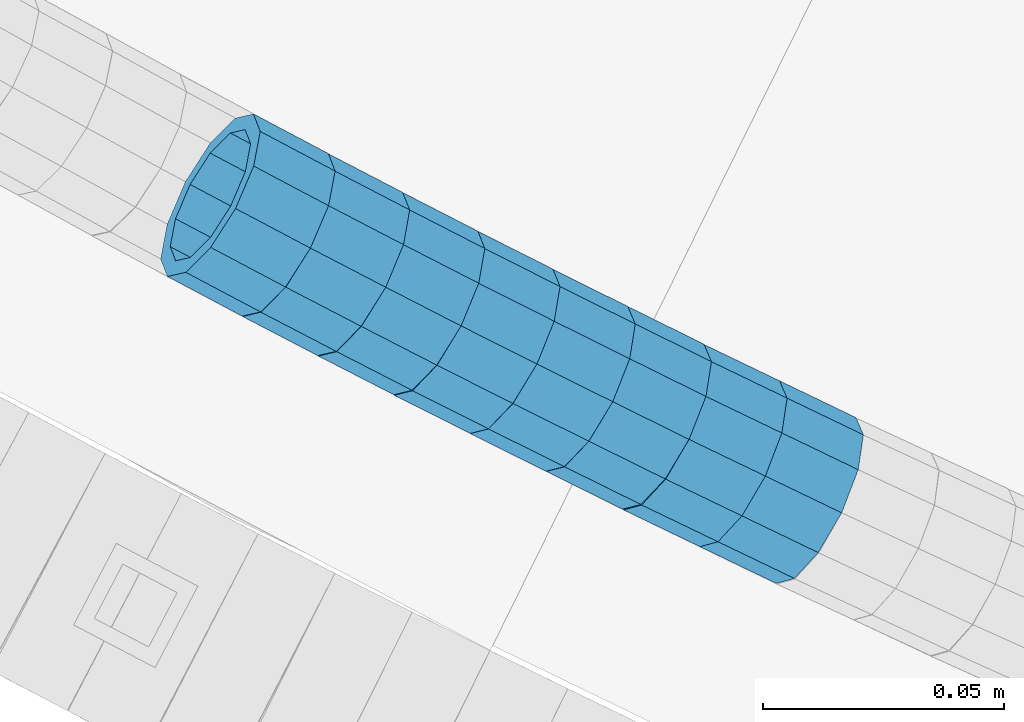
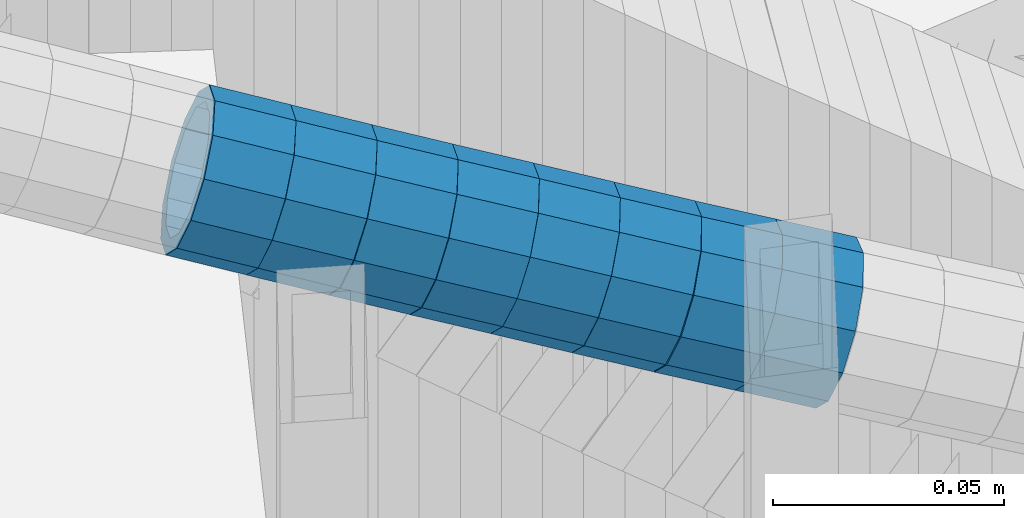
# One storey, part 647 of 975: 8 beams.
"""IFC2X3 building model written with IfcOpenShell, lengths in millimetres."""

import ifcopenshell
import ifcopenshell.guid

model = None  # the IFC model being written
_history = None  # IfcOwnerHistory: only IFC2X3 demands one
_inside = {}  # id of a spatial element -> (the spatial element, [elements in it])
_under = {}  # id of a project, library or spatial element -> (it, [spatial elements below it])
_declared = {}  # id of a project -> (the project, [libraries it declares])
_typed = {}  # id of a type object -> (the type object, [elements of that type])
_made_of = {}  # id of a material, layer set ... -> (it, [elements and type objects made of it])


def new_model(schema):
    """Start an empty IFC model of exactly this schema.

    Asked for "IFC4X3", IfcOpenShell would pick the latest addendum, in which some entities
    have other attributes; the version numbers below select the first issue.
    IFC2X3 requires an IfcOwnerHistory on every rooted entity: one is made here for all.
    """
    global model, _history
    if schema == "IFC4X3":
        model = ifcopenshell.file(schema_version=(4, 3, 0, 0))
    else:
        model = ifcopenshell.file(schema=schema)
    _inside.clear()
    _under.clear()
    _declared.clear()
    _typed.clear()
    _made_of.clear()
    _history = None
    if model.schema == "IFC2X3":
        org = make("IfcOrganization", Name="unknown")
        user = make(
            "IfcPersonAndOrganization",
            ThePerson=make("IfcPerson", FamilyName="unknown"),
            TheOrganization=org,
        )
        app = make(
            "IfcApplication",
            ApplicationDeveloper=org,
            Version="unknown",
            ApplicationFullName="unknown",
            ApplicationIdentifier="unknown",
        )
        _history = make(
            "IfcOwnerHistory",
            OwningUser=user,
            OwningApplication=app,
            ChangeAction="ADDED",
            CreationDate=0,
        )
    return model


def make(cls, **values):
    """One entity of the class cls with the attributes given. An attribute that is None is left unset."""
    return model.create_entity(
        cls, **{name: value for name, value in values.items() if value is not None}
    )


def rooted(cls, **values):
    """An entity with a GlobalId (a new one), such as an element, a storey or a relation."""
    return make(cls, GlobalId=ifcopenshell.guid.new(), OwnerHistory=_history, **values)


def si_unit(unit_type, name, prefix=None):
    """IfcSIUnit, for example si_unit("LENGTHUNIT", "METRE", prefix="MILLI")."""
    return make("IfcSIUnit", UnitType=unit_type, Prefix=prefix, Name=name)


def assignment(units):
    """IfcUnitAssignment: the units of a project."""
    return None if units is None else make("IfcUnitAssignment", Units=units)


def point(xyz):
    """IfcCartesianPoint."""
    return None if xyz is None else make("IfcCartesianPoint", Coordinates=xyz)


def direction(xyz):
    """IfcDirection."""
    return None if xyz is None else make("IfcDirection", DirectionRatios=xyz)


def frame(location, z_axis=None, x_axis=None):
    """IfcAxis2Placement3D, a coordinate frame: its origin and axes. An axis left out is left unset."""
    return make(
        "IfcAxis2Placement3D",
        Location=point(location),
        Axis=direction(z_axis),
        RefDirection=direction(x_axis),
    )


def origin_with_axes():
    """The frame at (0, 0, 0) with the z axis (0, 0, 1) and the x axis (1, 0, 0) written out."""
    return frame((0.0, 0.0, 0.0), z_axis=(0.0, 0.0, 1.0), x_axis=(1.0, 0.0, 0.0))


def place(relative_to, where):
    """IfcLocalPlacement: puts the frame where relative to a parent placement (None: the world)."""
    return make(
        "IfcLocalPlacement", PlacementRelTo=relative_to, RelativePlacement=where
    )


def context(
    kind, dimensions, precision=None, world=None, true_north=None, identifier=None
):
    """IfcGeometricRepresentationContext, for example the 3D "Model" context."""
    return make(
        "IfcGeometricRepresentationContext",
        ContextIdentifier=identifier,
        ContextType=kind,
        CoordinateSpaceDimension=dimensions,
        Precision=precision,
        WorldCoordinateSystem=world,
        TrueNorth=true_north,
    )


def subcontext(parent, identifier, kind, view, scale=None):
    """IfcGeometricRepresentationSubContext, for example "Body" below "Model"."""
    return make(
        "IfcGeometricRepresentationSubContext",
        ContextIdentifier=identifier,
        ContextType=kind,
        ParentContext=parent,
        TargetScale=scale,
        TargetView=view,
    )


def project(units=None, contexts=None):
    """IfcProject with its units and contexts."""
    return rooted(
        "IfcProject",
        Name="project",
        RepresentationContexts=contexts,
        UnitsInContext=assignment(units),
    )


def spatial(cls, under=None, at=None, **own):
    """A site, building, storey or space (cls), placed at a placement, below another one or the project."""
    s = rooted(cls, ObjectPlacement=at, **own)
    if under is not None:
        _under.setdefault(under.id(), (under, []))[1].append(s)
    return s


def faces_of(points, faces, orient=None, outer=None):
    """IfcFace entities. A face is a list of loops; a loop is a list of indices into points, from 0.

    orient and outer hold one flag for each loop. By default every Orientation is true, the
    first loop of a face is its IfcFaceOuterBound and the others are IfcFaceBound.
    """
    made = []
    for i, loops in enumerate(faces):
        bounds = []
        for j, loop in enumerate(loops):
            is_outer = j == 0 if outer is None else outer[i][j]
            bounds.append(
                make(
                    "IfcFaceOuterBound" if is_outer else "IfcFaceBound",
                    Bound=make("IfcPolyLoop", Polygon=[points[k] for k in loop]),
                    Orientation=True if orient is None else orient[i][j],
                )
            )
        made.append(make("IfcFace", Bounds=bounds))
    return made


def faceted_brep(points, faces, orient=None, outer=None, voids=None):
    """IfcFacetedBrep: a solid bounded by flat faces; with voids (closed shells), ...WithVoids."""
    shared = [point(p) for p in points]
    hull = make("IfcClosedShell", CfsFaces=faces_of(shared, faces, orient, outer))
    if voids is None:
        return make("IfcFacetedBrep", Outer=hull)
    return make(
        "IfcFacetedBrepWithVoids",
        Outer=hull,
        Voids=[
            make(cls, CfsFaces=faces_of(shared, fs, o, b)) for cls, fs, o, b in voids
        ],
    )


def shape(context_of_items, identifier, shape_type, items):
    """IfcShapeRepresentation: the items that make up one representation, for example the "Body"."""
    return make(
        "IfcShapeRepresentation",
        ContextOfItems=context_of_items,
        RepresentationIdentifier=identifier,
        RepresentationType=shape_type,
        Items=items,
    )


def material(Name=None, Category=None):
    """IfcMaterial."""
    return make("IfcMaterial", Name=Name, Category=Category)


def made_of(thing, what):
    """Note that an element or type object is made of a material, layer set ...; save() writes the relation."""
    if what is not None:
        _made_of.setdefault(what.id(), (what, []))[1].append(thing)
    return thing


def type_object(cls, material=None, **own):
    """A type object (cls), such as IfcWallType, which elements share."""
    return made_of(rooted(cls, **own), material)


def element(
    cls,
    number,
    at=None,
    inside=None,
    cuts=None,
    type_object=None,
    material=None,
    context=None,
    identifier="Body",
    shape_type=None,
    held_by="IfcProductDefinitionShape",
    body=None,
    shapes=None,
    **own,
):
    """One element of the class cls, such as IfcWall. Its Tag is "e" and its number.

    at: its placement. inside: the storey or other place that contains it. cuts: it is an
    opening in that element (IfcRelVoidsElement). A single representation is given by context,
    identifier, shape_type and body (its items); several are given by shapes. held_by: the class
    of the entity that holds the representations. save() writes the other relations.
    """
    e = rooted(cls, Tag="e%d" % number, ObjectPlacement=at, **own)
    if body is not None:
        shapes = [shape(context, identifier, shape_type, body)]
    if shapes is not None:
        e.Representation = make(held_by, Representations=shapes)
    if inside is not None:
        _inside.setdefault(inside.id(), (inside, []))[1].append(e)
    if cuts is not None:
        rooted(
            "IfcRelVoidsElement", RelatingBuildingElement=cuts, RelatedOpeningElement=e
        )
    if type_object is not None:
        _typed.setdefault(type_object.id(), (type_object, []))[1].append(e)
    return made_of(e, material)


def aggregate(whole, parts):
    """IfcRelAggregates: a whole, such as a stair, and the parts it consists of."""
    return rooted("IfcRelAggregates", RelatingObject=whole, RelatedObjects=parts)


def save(model, path):
    """Write the relations noted so far, then the file.

    IfcRelAggregates (storeys below a building ...), IfcRelContainedInSpatialStructure (elements
    in a storey), IfcRelDefinesByType, IfcRelAssociatesMaterial and IfcRelDeclares: one each for
    every whole, place, type object, material and project.
    """
    for whole, parts in _under.values():
        aggregate(whole, parts)
    for where, things in _inside.values():
        rooted(
            "IfcRelContainedInSpatialStructure",
            RelatedElements=things,
            RelatingStructure=where,
        )
    for kind, things in _typed.values():
        rooted("IfcRelDefinesByType", RelatedObjects=things, RelatingType=kind)
    for what, things in _made_of.values():
        rooted("IfcRelAssociatesMaterial", RelatedObjects=things, RelatingMaterial=what)
    for by, libraries in _declared.values():
        rooted("IfcRelDeclares", RelatingContext=by, RelatedDefinitions=libraries)
    model.write(path)


model = new_model("IFC2X3")

# Units and contexts
model_context = context("Model", 3, precision=1e-05, world=origin_with_axes())
body_context = subcontext(model_context, "Body", "Model", "MODEL_VIEW")
ifc_project = project(units=[si_unit("LENGTHUNIT", "METRE", prefix="MILLI"), si_unit("AREAUNIT", "SQUARE_METRE"), si_unit("VOLUMEUNIT", "CUBIC_METRE"), si_unit("MASSUNIT", "GRAM", prefix="KILO"), si_unit("TIMEUNIT", "SECOND"), si_unit("PLANEANGLEUNIT", "RADIAN"), si_unit("SOLIDANGLEUNIT", "STERADIAN"), si_unit("THERMODYNAMICTEMPERATUREUNIT", "DEGREE_CELSIUS"), si_unit("LUMINOUSINTENSITYUNIT", "LUMEN")], contexts=[model_context])

# Site, building, storey
site_placement = place(None, origin_with_axes())
site = spatial("IfcSite", under=ifc_project, at=site_placement, CompositionType="ELEMENT")
building_placement = place(site_placement, origin_with_axes())
building = spatial("IfcBuilding", under=site, at=building_placement, Name="Undefined", CompositionType="ELEMENT")
storey_placement = place(building_placement, origin_with_axes())
storey = spatial("IfcBuildingStorey", under=building, at=storey_placement, Name="Undefined", CompositionType="ELEMENT", Elevation=0.0)

# Beams
ifc_material = material()
beam_type = type_object("IfcBeamType", PredefinedType="NOTDEFINED")
beam_1_placement = place(storey_placement, frame((33416.0911510249, 947.261249186735, 4658.7831039662), z_axis=(0.467625681681325, 0.883926593011024, 9.3239577836357e-11), x_axis=(0.840630248711219, -0.444720518847201, -0.309134994893801)))
element("IfcBeam", 1, at=beam_1_placement, inside=storey, type_object=beam_type, material=ifc_material, Name="WALL", context=body_context, shape_type="Brep", body=[
    faceted_brep([(-2.1246523829177e-07, -15.367000000002, 0.0), (-1.83998054126278e-07, -13.3082123799541, 7.68350000000009), (18.4442402933746, -13.3082123799431, 7.68349999998463), (18.4442402933928, -15.3669999999893, -3.63797880709171e-12), (-1.06232619145885e-07, -7.68349999999919, 13.3082123799559), (18.4442402933564, -7.68349999998281, 13.308212379925), (-3.63797880709171e-12, 3.63797880709171e-12, 15.3670000000002), (18.4442402933455, 1.81898940354586e-11, 15.3669999999584), (1.06225343188271e-07, 7.68350000000646, 13.3082123799559), (18.4442402933419, 7.68350000001737, 13.3082123799104), (1.8399441614747e-07, 13.308212379965, 7.68350000000009), (18.4442402933528, 13.3082123799722, 7.68349999996281), (2.12461600312963e-07, 15.3670000000093, 0.0), (18.4442402933637, 15.3670000000129, -2.5465851649642e-11), (1.8399441614747e-07, 13.308212379965, -7.68350000000009), (18.4442402933855, 13.308212379965, -7.6835000000101), (1.06225343188271e-07, 7.68350000000646, -13.3082123799559), (18.4442402934037, 7.68350000000646, -13.3082123799541), (-3.63797880709171e-12, 3.63797880709171e-12, -15.3670000000002), (18.444240293411, 5.45696821063757e-12, -15.3669999999911), (-1.06232619145885e-07, -7.68349999999919, -13.3082123799559), (18.4442402934146, -7.68349999999373, -13.3082123799431), (-1.83998054126278e-07, -13.3082123799541, -7.68350000000009), (18.4442402934037, -13.3082123799468, -7.68349999999191), (-2.63386027654633e-07, -19.0500000000029, 0.0), (-2.28097633225843e-07, -16.4977839420972, -9.52499999999964), (18.444240293411, -16.4977839420862, -9.5249999999869), (18.4442402933964, -19.0499999999902, 0.0), (-1.31691194837913e-07, -9.52500000000146, -16.4977839420935), (18.4442402934219, -9.524999999996, -16.4977839420717), (-3.63797880709171e-12, 3.63797880709171e-12, -19.0500000000002), (18.4442402934183, 3.63797880709171e-12, -19.0499999999847), (1.31687556859106e-07, 9.52500000000509, -16.4977839420935), (18.4442402934073, 9.52500000000509, -16.4977839420899), (2.28097633225843e-07, 16.4977839421044, -9.52499999999964), (18.4442402933855, 16.4977839421008, -9.52500000001601), (2.63382389675826e-07, 19.0500000000138, 0.0), (18.4442402933637, 19.0500000000138, -2.91038304567337e-11), (2.28097633225843e-07, 16.4977839421044, 9.52499999999964), (18.4442402933419, 16.4977839421117, 9.52499999995052), (1.31687556859106e-07, 9.52500000000509, 16.4977839420935), (18.4442402933346, 9.52500000001965, 16.4977839420426), (-3.63797880709171e-12, 3.63797880709171e-12, 19.0500000000002), (18.4442402933346, 2.00088834390044e-11, 19.0499999999483), (-1.31691194837913e-07, -9.52500000000146, 16.4977839420935), (18.4442402933528, -9.52499999998145, 16.4977839420571), (-2.28097633225843e-07, -16.4977839420972, 9.52499999999964), (18.4442402933746, -16.497783942079, 9.52499999998327)], [[[0, 1, 2, 3]], [[1, 4, 5, 2]], [[4, 6, 7, 5]], [[6, 8, 9, 7]], [[8, 10, 11, 9]], [[10, 12, 13, 11]], [[12, 14, 15, 13]], [[14, 16, 17, 15]], [[16, 18, 19, 17]], [[18, 20, 21, 19]], [[20, 22, 23, 21]], [[22, 0, 3, 23]], [[24, 25, 26, 27]], [[25, 28, 29, 26]], [[28, 30, 31, 29]], [[30, 32, 33, 31]], [[32, 34, 35, 33]], [[34, 36, 37, 35]], [[36, 38, 39, 37]], [[38, 40, 41, 39]], [[40, 42, 43, 41]], [[42, 44, 45, 43]], [[44, 46, 47, 45]], [[46, 24, 27, 47]], [[29, 31, 33, 35, 37, 39, 41, 43, 45, 47, 27, 26], [5, 7, 9, 11, 13, 15, 17, 19, 21, 23, 3, 2]], [[46, 44, 42, 40, 38, 36, 34, 32, 30, 28, 25, 24], [22, 20, 18, 16, 14, 12, 10, 8, 6, 4, 1, 0]]]),
])
beam_2_placement = place(storey_placement, frame((33431.4988890228, 939.058133171127, 4653.10939389634), z_axis=(0.460815270795851, 0.887496076724481, 1.78888512891718e-11), x_axis=(0.842800104689895, -0.437607746838989, -0.31334875688473)))
element("IfcBeam", 2, at=beam_2_placement, inside=storey, type_object=beam_type, material=ifc_material, Name="WALL", context=body_context, shape_type="Brep", body=[
    faceted_brep([(-2.1246523829177e-07, -15.367000000002, 0.0), (-1.83998054126278e-07, -13.3082123799541, 7.68350000000009), (18.5143187830763, -13.3082123799722, 7.68350000001374), (18.5143187830618, -15.3670000000093, 3.63797880709171e-12), (-1.06232619145885e-07, -7.68349999999919, 13.3082123799559), (18.5143187830836, -7.68350000002101, 13.3082123799722), (-3.63797880709171e-12, 3.63797880709171e-12, 15.3670000000002), (18.5143187830763, -1.81898940354586e-11, 15.3670000000166), (1.06225343188271e-07, 7.68350000000646, 13.3082123799559), (18.5143187830581, 7.68349999999009, 13.3082123799613), (1.8399441614747e-07, 13.308212379965, 7.68350000000009), (18.5143187830363, 13.3082123799559, 7.68349999999191), (2.12461600312963e-07, 15.3670000000093, 0.0), (18.5143187830108, 15.3670000000111, -2.18278728425503e-11), (1.8399441614747e-07, 13.308212379965, -7.68350000000009), (18.514318782989, 13.3082123799722, -7.68350000003193), (1.06225343188271e-07, 7.68350000000646, -13.3082123799559), (18.5143187829854, 7.68350000002101, -13.3082123799904), (-3.63797880709171e-12, 3.63797880709171e-12, -15.3670000000002), (18.5143187829926, 1.81898940354586e-11, -15.3670000000311), (-1.06232619145885e-07, -7.68349999999919, -13.3082123799559), (18.5143187830108, -7.68349999999191, -13.3082123799795), (-1.83998054126278e-07, -13.3082123799541, -7.68350000000009), (18.5143187830363, -13.3082123799559, -7.6835000000101), (-2.63386027654633e-07, -19.0500000000029, 0.0), (-2.28097633225843e-07, -16.4977839420972, -9.52499999999964), (18.5143187830363, -16.4977839420935, -9.52500000000873), (18.5143187830654, -19.0500000000102, 7.27595761418343e-12), (-1.31691194837913e-07, -9.52500000000146, -16.4977839420935), (18.5143187830035, -9.5249999999869, -16.497783942119), (-3.63797880709171e-12, 3.63797880709171e-12, -19.0500000000002), (18.5143187829854, 2.00088834390044e-11, -19.0500000000357), (1.31687556859106e-07, 9.52500000000509, -16.4977839420935), (18.5143187829744, 9.5250000000251, -16.4977839421408), (2.28097633225843e-07, 16.4977839421044, -9.52499999999964), (18.5143187829854, 16.4977839421135, -9.52500000003783), (2.63382389675826e-07, 19.0500000000138, 0.0), (18.5143187830035, 19.050000000012, -2.5465851649642e-11), (2.28097633225843e-07, 16.4977839421044, 9.52499999999964), (18.5143187830326, 16.4977839420935, 9.52499999999054), (1.31687556859106e-07, 9.52500000000509, 16.4977839420935), (18.5143187830654, 9.52499999998872, 16.4977839421008), (-3.63797880709171e-12, 3.63797880709171e-12, 19.0500000000002), (18.5143187830836, -1.81898940354586e-11, 19.0500000000211), (-1.31691194837913e-07, -9.52500000000146, 16.4977839420935), (18.5143187830981, -9.52500000002328, 16.4977839421226), (-2.28097633225843e-07, -16.4977839420972, 9.52499999999964), (18.5143187830872, -16.4977839421135, 9.52500000001965)], [[[0, 1, 2, 3]], [[1, 4, 5, 2]], [[4, 6, 7, 5]], [[6, 8, 9, 7]], [[8, 10, 11, 9]], [[10, 12, 13, 11]], [[12, 14, 15, 13]], [[14, 16, 17, 15]], [[16, 18, 19, 17]], [[18, 20, 21, 19]], [[20, 22, 23, 21]], [[22, 0, 3, 23]], [[24, 25, 26, 27]], [[25, 28, 29, 26]], [[28, 30, 31, 29]], [[30, 32, 33, 31]], [[32, 34, 35, 33]], [[34, 36, 37, 35]], [[36, 38, 39, 37]], [[38, 40, 41, 39]], [[40, 42, 43, 41]], [[42, 44, 45, 43]], [[44, 46, 47, 45]], [[46, 24, 27, 47]], [[29, 31, 33, 35, 37, 39, 41, 43, 45, 47, 27, 26], [5, 7, 9, 11, 13, 15, 17, 19, 21, 23, 3, 2]], [[46, 44, 42, 40, 38, 36, 34, 32, 30, 28, 25, 24], [22, 20, 18, 16, 14, 12, 10, 8, 6, 4, 1, 0]]]),
])
beam_3_placement = place(storey_placement, frame((33447.1554574251, 930.895163959416, 4647.28347009415), z_axis=(0.456316647774038, 0.889817462721577, 2.40652298089117e-11), x_axis=(0.846215471031534, -0.433956652016189, -0.309194115011557)))
element("IfcBeam", 3, at=beam_3_placement, inside=storey, type_object=beam_type, material=ifc_material, Name="WALL", context=body_context, shape_type="Brep", body=[
    faceted_brep([(-2.1246523829177e-07, -15.367000000002, 0.0), (-1.83998054126278e-07, -13.3082123799541, 7.68350000000009), (18.4442402933746, -13.3082123799431, 7.68349999998463), (18.4442402933928, -15.3669999999893, -3.63797880709171e-12), (-1.06232619145885e-07, -7.68349999999919, 13.3082123799559), (18.4442402933564, -7.68349999998281, 13.308212379925), (-3.63797880709171e-12, 3.63797880709171e-12, 15.3670000000002), (18.4442402933455, 1.81898940354586e-11, 15.3669999999584), (1.06225343188271e-07, 7.68350000000646, 13.3082123799559), (18.4442402933419, 7.68350000001737, 13.3082123799104), (1.8399441614747e-07, 13.308212379965, 7.68350000000009), (18.4442402933528, 13.3082123799722, 7.68349999996281), (2.12461600312963e-07, 15.3670000000093, 0.0), (18.4442402933637, 15.3670000000129, -2.5465851649642e-11), (1.8399441614747e-07, 13.308212379965, -7.68350000000009), (18.4442402933855, 13.308212379965, -7.6835000000101), (1.06225343188271e-07, 7.68350000000646, -13.3082123799559), (18.4442402934037, 7.68350000000646, -13.3082123799541), (-3.63797880709171e-12, 3.63797880709171e-12, -15.3670000000002), (18.444240293411, 5.45696821063757e-12, -15.3669999999911), (-1.06232619145885e-07, -7.68349999999919, -13.3082123799559), (18.4442402934146, -7.68349999999373, -13.3082123799431), (-1.83998054126278e-07, -13.3082123799541, -7.68350000000009), (18.4442402934037, -13.3082123799468, -7.68349999999191), (-2.63386027654633e-07, -19.0500000000029, 0.0), (-2.28097633225843e-07, -16.4977839420972, -9.52499999999964), (18.444240293411, -16.4977839420862, -9.5249999999869), (18.4442402933964, -19.0499999999902, 0.0), (-1.31691194837913e-07, -9.52500000000146, -16.4977839420935), (18.4442402934219, -9.524999999996, -16.4977839420717), (-3.63797880709171e-12, 3.63797880709171e-12, -19.0500000000002), (18.4442402934183, 3.63797880709171e-12, -19.0499999999847), (1.31687556859106e-07, 9.52500000000509, -16.4977839420935), (18.4442402934073, 9.52500000000509, -16.4977839420899), (2.28097633225843e-07, 16.4977839421044, -9.52499999999964), (18.4442402933855, 16.4977839421008, -9.52500000001601), (2.63382389675826e-07, 19.0500000000138, 0.0), (18.4442402933637, 19.0500000000138, -2.91038304567337e-11), (2.28097633225843e-07, 16.4977839421044, 9.52499999999964), (18.4442402933419, 16.4977839421117, 9.52499999995052), (1.31687556859106e-07, 9.52500000000509, 16.4977839420935), (18.4442402933346, 9.52500000001965, 16.4977839420426), (-3.63797880709171e-12, 3.63797880709171e-12, 19.0500000000002), (18.4442402933346, 2.00088834390044e-11, 19.0499999999483), (-1.31691194837913e-07, -9.52500000000146, 16.4977839420935), (18.4442402933528, -9.52499999998145, 16.4977839420571), (-2.28097633225843e-07, -16.4977839420972, 9.52499999999964), (18.4442402933746, -16.497783942079, 9.52499999998327)], [[[0, 1, 2, 3]], [[1, 4, 5, 2]], [[4, 6, 7, 5]], [[6, 8, 9, 7]], [[8, 10, 11, 9]], [[10, 12, 13, 11]], [[12, 14, 15, 13]], [[14, 16, 17, 15]], [[16, 18, 19, 17]], [[18, 20, 21, 19]], [[20, 22, 23, 21]], [[22, 0, 3, 23]], [[24, 25, 26, 27]], [[25, 28, 29, 26]], [[28, 30, 31, 29]], [[30, 32, 33, 31]], [[32, 34, 35, 33]], [[34, 36, 37, 35]], [[36, 38, 39, 37]], [[38, 40, 41, 39]], [[40, 42, 43, 41]], [[42, 44, 45, 43]], [[44, 46, 47, 45]], [[46, 24, 27, 47]], [[29, 31, 33, 35, 37, 39, 41, 43, 45, 47, 27, 26], [5, 7, 9, 11, 13, 15, 17, 19, 21, 23, 3, 2]], [[46, 44, 42, 40, 38, 36, 34, 32, 30, 28, 25, 24], [22, 20, 18, 16, 14, 12, 10, 8, 6, 4, 1, 0]]]),
])
beam_4_placement = place(storey_placement, frame((33462.7469060079, 922.848964169465, 4641.5791512697), z_axis=(0.449488036364084, 0.893286351158216, 2.07292941922788e-10), x_axis=(0.849716897215039, -0.427564553108204, -0.308495944078084)))
element("IfcBeam", 4, at=beam_4_placement, inside=storey, type_object=beam_type, material=ifc_material, Name="WALL", context=body_context, shape_type="Brep", body=[
    faceted_brep([(-2.1246523829177e-07, -15.367000000002, 0.0), (-1.83998054126278e-07, -13.3082123799541, 7.68350000000009), (18.4753890351749, -13.3082123799613, 7.6835000000101), (18.4753890351676, -15.3670000000056, 0.0), (-1.06232619145885e-07, -7.68349999999919, 13.3082123799559), (18.4753890351822, -7.6835000000101, 13.3082123799686), (-3.63797880709171e-12, 3.63797880709171e-12, 15.3670000000002), (18.4753890351967, -1.2732925824821e-11, 15.3670000000238), (1.06225343188271e-07, 7.68350000000646, 13.3082123799559), (18.475389035204, 7.68349999998463, 13.3082123799832), (1.8399441614747e-07, 13.308212379965, 7.68350000000009), (18.4753890352004, 13.3082123799395, 7.68350000002465), (2.12461600312963e-07, 15.3670000000093, 0.0), (18.4753890351967, 15.3669999999838, 2.5465851649642e-11), (1.8399441614747e-07, 13.308212379965, -7.68350000000009), (18.4753890351894, 13.3082123799413, -7.68349999998463), (1.06225343188271e-07, 7.68350000000646, -13.3082123799559), (18.4753890351749, 7.68349999998827, -13.3082123799468), (-3.63797880709171e-12, 3.63797880709171e-12, -15.3670000000002), (18.4753890351676, -1.09139364212751e-11, -15.3669999999947), (-1.06232619145885e-07, -7.68349999999919, -13.3082123799559), (18.4753890351676, -7.68350000000646, -13.3082123799577), (-1.83998054126278e-07, -13.3082123799541, -7.68350000000009), (18.4753890351567, -13.3082123799613, -7.68350000000282), (-2.63386027654633e-07, -19.0500000000029, 0.0), (-2.28097633225843e-07, -16.4977839420972, -9.52499999999964), (18.4753890351567, -16.4977839420972, -9.52500000000873), (18.4753890351676, -19.0500000000065, 0.0), (-1.31691194837913e-07, -9.52500000000146, -16.4977839420935), (18.475389035164, -9.52500000000873, -16.4977839420972), (-3.63797880709171e-12, 3.63797880709171e-12, -19.0500000000002), (18.475389035164, -9.09494701772928e-12, -19.0499999999993), (1.31687556859106e-07, 9.52500000000509, -16.4977839420935), (18.4753890351822, 9.5249999999869, -16.497783942079), (2.28097633225843e-07, 16.4977839421044, -9.52499999999964), (18.4753890351931, 16.497783942079, -9.52499999997963), (2.63382389675826e-07, 19.0500000000138, 0.0), (18.475389035204, 19.0499999999847, 2.91038304567337e-11), (2.28097633225843e-07, 16.4977839421044, 9.52499999999964), (18.4753890352113, 16.4977839420753, 9.5250000000342), (1.31687556859106e-07, 9.52500000000509, 16.4977839420935), (18.475389035204, 9.52499999998327, 16.4977839421226), (-3.63797880709171e-12, 3.63797880709171e-12, 19.0500000000002), (18.4753890352004, -1.45519152283669e-11, 19.0500000000284), (-1.31691194837913e-07, -9.52500000000146, 16.4977839420935), (18.4753890351858, -9.52500000000873, 16.4977839421081), (-2.28097633225843e-07, -16.4977839420972, 9.52499999999964), (18.4753890351749, -16.4977839421008, 9.52500000000509)], [[[0, 1, 2, 3]], [[1, 4, 5, 2]], [[4, 6, 7, 5]], [[6, 8, 9, 7]], [[8, 10, 11, 9]], [[10, 12, 13, 11]], [[12, 14, 15, 13]], [[14, 16, 17, 15]], [[16, 18, 19, 17]], [[18, 20, 21, 19]], [[20, 22, 23, 21]], [[22, 0, 3, 23]], [[24, 25, 26, 27]], [[25, 28, 29, 26]], [[28, 30, 31, 29]], [[30, 32, 33, 31]], [[32, 34, 35, 33]], [[34, 36, 37, 35]], [[36, 38, 39, 37]], [[38, 40, 41, 39]], [[40, 42, 43, 41]], [[42, 44, 45, 43]], [[44, 46, 47, 45]], [[46, 24, 27, 47]], [[29, 31, 33, 35, 37, 39, 41, 43, 45, 47, 27, 26], [5, 7, 9, 11, 13, 15, 17, 19, 21, 23, 3, 2]], [[46, 44, 42, 40, 38, 36, 34, 32, 30, 28, 25, 24], [22, 20, 18, 16, 14, 12, 10, 8, 6, 4, 1, 0]]]),
])
beam_5_placement = place(storey_placement, frame((33478.3378815538, 914.969691555199, 4635.91413137574), z_axis=(0.444930445702484, 0.895565127998511, 8.79335857462137e-11), x_axis=(0.850240068166291, -0.422412263082608, -0.314101427061402)))
element("IfcBeam", 5, at=beam_5_placement, inside=storey, type_object=beam_type, material=ifc_material, Name="WALL", context=body_context, shape_type="Brep", body=[
    faceted_brep([(-2.1246523829177e-07, -15.367000000002, 0.0), (-1.83998054126278e-07, -13.3082123799541, 7.68350000000009), (18.4672683416502, -13.3082123799759, 7.68350000002465), (18.4672683416611, -15.3670000000202, 3.09228198602796e-11), (-1.06232619145885e-07, -7.68349999999919, 13.3082123799559), (18.467268341632, -7.68350000001737, 13.3082123799704), (-3.63797880709171e-12, 3.63797880709171e-12, 15.3670000000002), (18.4672683416175, -1.09139364212751e-11, 15.3670000000075), (1.06225343188271e-07, 7.68350000000646, 13.3082123799559), (18.4672683416102, 7.68349999998827, 13.3082123799613), (1.8399441614747e-07, 13.308212379965, 7.68350000000009), (18.4672683416138, 13.3082123799468, 7.68350000000464), (2.12461600312963e-07, 15.3670000000093, 0.0), (18.4672683416138, 15.3669999999929, 5.45696821063757e-12), (1.8399441614747e-07, 13.308212379965, -7.68350000000009), (18.4672683416284, 13.308212379945, -7.68349999998827), (1.06225343188271e-07, 7.68350000000646, -13.3082123799559), (18.4672683416429, 7.68349999998827, -13.3082123799359), (-3.63797880709171e-12, 3.63797880709171e-12, -15.3670000000002), (18.4672683416611, -1.63709046319127e-11, -15.3669999999747), (-1.06232619145885e-07, -7.68349999999919, -13.3082123799559), (18.4672683416647, -7.68350000001919, -13.3082123799268), (-1.83998054126278e-07, -13.3082123799541, -7.68350000000009), (18.4672683416684, -13.3082123799759, -7.68349999997008), (-2.63386027654633e-07, -19.0500000000029, 0.0), (-2.28097633225843e-07, -16.4977839420972, -9.52499999999964), (18.4672683416793, -16.4977839421172, -9.52499999996508), (18.467268341672, -19.0500000000247, 3.27418092638254e-11), (-1.31691194837913e-07, -9.52500000000146, -16.4977839420935), (18.4672683416757, -9.52500000002328, -16.497783942059), (-3.63797880709171e-12, 3.63797880709171e-12, -19.0500000000002), (18.4672683416611, -1.45519152283669e-11, -19.0499999999738), (1.31687556859106e-07, 9.52500000000509, -16.4977839420935), (18.4672683416502, 9.5249999999869, -16.4977839420735), (2.28097633225843e-07, 16.4977839421044, -9.52499999999964), (18.4672683416247, 16.4977839420862, -9.52499999998872), (2.63382389675826e-07, 19.0500000000138, 0.0), (18.4672683416029, 19.0499999999956, 1.81898940354586e-12), (2.28097633225843e-07, 16.4977839421044, 9.52499999999964), (18.4672683416065, 16.4977839420862, 9.52500000000146), (1.31687556859106e-07, 9.52500000000509, 16.4977839420935), (18.4672683415993, 9.52499999999236, 16.4977839420917), (-3.63797880709171e-12, 3.63797880709171e-12, 19.0500000000002), (18.4672683416138, -1.45519152283669e-11, 19.0500000000084), (-1.31691194837913e-07, -9.52500000000146, 16.4977839420935), (18.4672683416356, -9.52500000001783, 16.4977839421117), (-2.28097633225843e-07, -16.4977839420972, 9.52499999999964), (18.4672683416538, -16.4977839421135, 9.5250000000251)], [[[0, 1, 2, 3]], [[1, 4, 5, 2]], [[4, 6, 7, 5]], [[6, 8, 9, 7]], [[8, 10, 11, 9]], [[10, 12, 13, 11]], [[12, 14, 15, 13]], [[14, 16, 17, 15]], [[16, 18, 19, 17]], [[18, 20, 21, 19]], [[20, 22, 23, 21]], [[22, 0, 3, 23]], [[24, 25, 26, 27]], [[25, 28, 29, 26]], [[28, 30, 31, 29]], [[30, 32, 33, 31]], [[32, 34, 35, 33]], [[34, 36, 37, 35]], [[36, 38, 39, 37]], [[38, 40, 41, 39]], [[40, 42, 43, 41]], [[42, 44, 45, 43]], [[44, 46, 47, 45]], [[46, 24, 27, 47]], [[29, 31, 33, 35, 37, 39, 41, 43, 45, 47, 27, 26], [5, 7, 9, 11, 13, 15, 17, 19, 21, 23, 3, 2]], [[46, 44, 42, 40, 38, 36, 34, 32, 30, 28, 25, 24], [22, 20, 18, 16, 14, 12, 10, 8, 6, 4, 1, 0]]]),
])
beam_6_placement = place(storey_placement, frame((33494.0557895983, 907.144000874222, 4630.10507295885), z_axis=(0.442667652479141, 0.896685758473171, 2.22678863792681e-10), x_axis=(0.851730363913507, -0.420474482957295, -0.312660512968235)))
element("IfcBeam", 6, at=beam_6_placement, inside=storey, type_object=beam_type, material=ifc_material, Name="WALL", context=body_context, shape_type="Brep", body=[
    faceted_brep([(-2.1246523829177e-07, -15.367000000002, 0.0), (-1.83998054126278e-07, -13.3082123799541, 7.68350000000009), (18.5504716921532, -13.3082123799668, 7.68350000001737), (18.5504716921569, -15.3670000000111, 1.81898940354586e-11), (-1.06232619145885e-07, -7.68349999999919, 13.3082123799559), (18.5504716921569, -7.68350000001192, 13.3082123799722), (-3.63797880709171e-12, 3.63797880709171e-12, 15.3670000000002), (18.5504716921641, -1.2732925824821e-11, 15.3670000000238), (1.06225343188271e-07, 7.68350000000646, 13.3082123799559), (18.5504716921714, 7.68349999998645, 13.3082123799868), (1.8399441614747e-07, 13.308212379965, 7.68350000000009), (18.5504716921787, 13.308212379945, 7.68350000003193), (2.12461600312963e-07, 15.3670000000093, 0.0), (18.5504716921787, 15.3669999999929, 3.27418092638254e-11), (1.8399441614747e-07, 13.308212379965, -7.68350000000009), (18.5504716921787, 13.3082123799522, -7.68349999997008), (1.06225343188271e-07, 7.68350000000646, -13.3082123799559), (18.5504716921787, 7.68349999999555, -13.3082123799213), (-3.63797880709171e-12, 3.63797880709171e-12, -15.3670000000002), (18.5504716921714, -3.63797880709171e-12, -15.3669999999765), (-1.06232619145885e-07, -7.68349999999919, -13.3082123799559), (18.5504716921641, -7.68350000000464, -13.3082123799359), (-1.83998054126278e-07, -13.3082123799541, -7.68350000000009), (18.5504716921605, -13.3082123799632, -7.683499999981), (-2.63386027654633e-07, -19.0500000000029, 0.0), (-2.28097633225843e-07, -16.4977839420972, -9.52499999999964), (18.5504716921569, -16.4977839421026, -9.52499999997963), (18.5504716921532, -19.0500000000102, 1.09139364212751e-11), (-1.31691194837913e-07, -9.52500000000146, -16.4977839420935), (18.5504716921605, -9.52500000000509, -16.4977839420681), (-3.63797880709171e-12, 3.63797880709171e-12, -19.0500000000002), (18.5504716921678, -1.81898940354586e-12, -19.0499999999774), (1.31687556859106e-07, 9.52500000000509, -16.4977839420935), (18.5504716921823, 9.52499999999782, -16.4977839420608), (2.28097633225843e-07, 16.4977839421044, -9.52499999999964), (18.550471692186, 16.4977839420881, -9.52499999996508), (2.63382389675826e-07, 19.0500000000138, 0.0), (18.550471692186, 19.049999999992, 3.63797880709171e-11), (2.28097633225843e-07, 16.4977839421044, 9.52499999999964), (18.5504716921787, 16.4977839420844, 9.52500000003056), (1.31687556859106e-07, 9.52500000000509, 16.4977839420935), (18.5504716921678, 9.52499999998872, 16.497783942119), (-3.63797880709171e-12, 3.63797880709171e-12, 19.0500000000002), (18.5504716921605, -1.2732925824821e-11, 19.0500000000211), (-1.31691194837913e-07, -9.52500000000146, 16.4977839420935), (18.5504716921569, -9.52500000001419, 16.4977839421117), (-2.28097633225843e-07, -16.4977839420972, 9.52499999999964), (18.5504716921532, -16.4977839421063, 9.52500000001601)], [[[0, 1, 2, 3]], [[1, 4, 5, 2]], [[4, 6, 7, 5]], [[6, 8, 9, 7]], [[8, 10, 11, 9]], [[10, 12, 13, 11]], [[12, 14, 15, 13]], [[14, 16, 17, 15]], [[16, 18, 19, 17]], [[18, 20, 21, 19]], [[20, 22, 23, 21]], [[22, 0, 3, 23]], [[24, 25, 26, 27]], [[25, 28, 29, 26]], [[28, 30, 31, 29]], [[30, 32, 33, 31]], [[32, 34, 35, 33]], [[34, 36, 37, 35]], [[36, 38, 39, 37]], [[38, 40, 41, 39]], [[40, 42, 43, 41]], [[42, 44, 45, 43]], [[44, 46, 47, 45]], [[46, 24, 27, 47]], [[29, 31, 33, 35, 37, 39, 41, 43, 45, 47, 27, 26], [5, 7, 9, 11, 13, 15, 17, 19, 21, 23, 3, 2]], [[46, 44, 42, 40, 38, 36, 34, 32, 30, 28, 25, 24], [22, 20, 18, 16, 14, 12, 10, 8, 6, 4, 1, 0]]]),
])
beam_7_placement = place(storey_placement, frame((33509.8889208397, 899.260458957218, 4624.2833574086), z_axis=(0.433472609828554, 0.901166741801106, 2.21989466808737e-11), x_axis=(0.857013954292699, -0.412234560140785, -0.309175920105567)))
element("IfcBeam", 7, at=beam_7_placement, inside=storey, type_object=beam_type, material=ifc_material, Name="WALL", context=body_context, shape_type="Brep", body=[
    faceted_brep([(-2.1246523829177e-07, -15.367000000002, 0.0), (-1.83998054126278e-07, -13.3082123799541, 7.68350000000009), (18.4442402933746, -13.3082123799431, 7.68349999998463), (18.4442402933928, -15.3669999999893, -3.63797880709171e-12), (-1.06232619145885e-07, -7.68349999999919, 13.3082123799559), (18.4442402933564, -7.68349999998281, 13.308212379925), (-3.63797880709171e-12, 3.63797880709171e-12, 15.3670000000002), (18.4442402933455, 1.81898940354586e-11, 15.3669999999584), (1.06225343188271e-07, 7.68350000000646, 13.3082123799559), (18.4442402933419, 7.68350000001737, 13.3082123799104), (1.8399441614747e-07, 13.308212379965, 7.68350000000009), (18.4442402933528, 13.3082123799722, 7.68349999996281), (2.12461600312963e-07, 15.3670000000093, 0.0), (18.4442402933637, 15.3670000000129, -2.5465851649642e-11), (1.8399441614747e-07, 13.308212379965, -7.68350000000009), (18.4442402933855, 13.308212379965, -7.6835000000101), (1.06225343188271e-07, 7.68350000000646, -13.3082123799559), (18.4442402934037, 7.68350000000646, -13.3082123799541), (-3.63797880709171e-12, 3.63797880709171e-12, -15.3670000000002), (18.444240293411, 5.45696821063757e-12, -15.3669999999911), (-1.06232619145885e-07, -7.68349999999919, -13.3082123799559), (18.4442402934146, -7.68349999999373, -13.3082123799431), (-1.83998054126278e-07, -13.3082123799541, -7.68350000000009), (18.4442402934037, -13.3082123799468, -7.68349999999191), (-2.63386027654633e-07, -19.0500000000029, 0.0), (-2.28097633225843e-07, -16.4977839420972, -9.52499999999964), (18.444240293411, -16.4977839420862, -9.5249999999869), (18.4442402933964, -19.0499999999902, 0.0), (-1.31691194837913e-07, -9.52500000000146, -16.4977839420935), (18.4442402934219, -9.524999999996, -16.4977839420717), (-3.63797880709171e-12, 3.63797880709171e-12, -19.0500000000002), (18.4442402934183, 3.63797880709171e-12, -19.0499999999847), (1.31687556859106e-07, 9.52500000000509, -16.4977839420935), (18.4442402934073, 9.52500000000509, -16.4977839420899), (2.28097633225843e-07, 16.4977839421044, -9.52499999999964), (18.4442402933855, 16.4977839421008, -9.52500000001601), (2.63382389675826e-07, 19.0500000000138, 0.0), (18.4442402933637, 19.0500000000138, -2.91038304567337e-11), (2.28097633225843e-07, 16.4977839421044, 9.52499999999964), (18.4442402933419, 16.4977839421117, 9.52499999995052), (1.31687556859106e-07, 9.52500000000509, 16.4977839420935), (18.4442402933346, 9.52500000001965, 16.4977839420426), (-3.63797880709171e-12, 3.63797880709171e-12, 19.0500000000002), (18.4442402933346, 2.00088834390044e-11, 19.0499999999483), (-1.31691194837913e-07, -9.52500000000146, 16.4977839420935), (18.4442402933528, -9.52499999998145, 16.4977839420571), (-2.28097633225843e-07, -16.4977839420972, 9.52499999999964), (18.4442402933746, -16.497783942079, 9.52499999998327)], [[[0, 1, 2, 3]], [[1, 4, 5, 2]], [[4, 6, 7, 5]], [[6, 8, 9, 7]], [[8, 10, 11, 9]], [[10, 12, 13, 11]], [[12, 14, 15, 13]], [[14, 16, 17, 15]], [[16, 18, 19, 17]], [[18, 20, 21, 19]], [[20, 22, 23, 21]], [[22, 0, 3, 23]], [[24, 25, 26, 27]], [[25, 28, 29, 26]], [[28, 30, 31, 29]], [[30, 32, 33, 31]], [[32, 34, 35, 33]], [[34, 36, 37, 35]], [[36, 38, 39, 37]], [[38, 40, 41, 39]], [[40, 42, 43, 41]], [[42, 44, 45, 43]], [[44, 46, 47, 45]], [[46, 24, 27, 47]], [[29, 31, 33, 35, 37, 39, 41, 43, 45, 47, 27, 26], [5, 7, 9, 11, 13, 15, 17, 19, 21, 23, 3, 2]], [[46, 44, 42, 40, 38, 36, 34, 32, 30, 28, 25, 24], [22, 20, 18, 16, 14, 12, 10, 8, 6, 4, 1, 0]]]),
])
beam_8_placement = place(storey_placement, frame((33525.6889208397, 891.660458957226, 4618.58335740856), z_axis=(0.433472609828554, 0.901166741801106, 2.21989466808737e-11), x_axis=(0.857013954292699, -0.412234560140785, -0.309175920105567)))
element("IfcBeam", 8, at=beam_8_placement, inside=storey, type_object=beam_type, material=ifc_material, Name="WALL", context=body_context, shape_type="Brep", body=[
    faceted_brep([(-2.1246523829177e-07, -15.367000000002, 0.0), (-1.83998054126278e-07, -13.3082123799541, 7.68350000000009), (18.4442402933746, -13.3082123799431, 7.68349999998463), (18.4442402933928, -15.3669999999893, -3.63797880709171e-12), (-1.06232619145885e-07, -7.68349999999919, 13.3082123799559), (18.4442402933564, -7.68349999998281, 13.308212379925), (-3.63797880709171e-12, 3.63797880709171e-12, 15.3670000000002), (18.4442402933455, 1.81898940354586e-11, 15.3669999999584), (1.06225343188271e-07, 7.68350000000646, 13.3082123799559), (18.4442402933419, 7.68350000001737, 13.3082123799104), (1.8399441614747e-07, 13.308212379965, 7.68350000000009), (18.4442402933528, 13.3082123799722, 7.68349999996281), (2.12461600312963e-07, 15.3670000000093, 0.0), (18.4442402933637, 15.3670000000129, -2.5465851649642e-11), (1.8399441614747e-07, 13.308212379965, -7.68350000000009), (18.4442402933855, 13.308212379965, -7.6835000000101), (1.06225343188271e-07, 7.68350000000646, -13.3082123799559), (18.4442402934037, 7.68350000000646, -13.3082123799541), (-3.63797880709171e-12, 3.63797880709171e-12, -15.3670000000002), (18.444240293411, 5.45696821063757e-12, -15.3669999999911), (-1.06232619145885e-07, -7.68349999999919, -13.3082123799559), (18.4442402934146, -7.68349999999373, -13.3082123799431), (-1.83998054126278e-07, -13.3082123799541, -7.68350000000009), (18.4442402934037, -13.3082123799468, -7.68349999999191), (-2.63386027654633e-07, -19.0500000000029, 0.0), (-2.28097633225843e-07, -16.4977839420972, -9.52499999999964), (18.444240293411, -16.4977839420862, -9.5249999999869), (18.4442402933964, -19.0499999999902, 0.0), (-1.31691194837913e-07, -9.52500000000146, -16.4977839420935), (18.4442402934219, -9.524999999996, -16.4977839420717), (-3.63797880709171e-12, 3.63797880709171e-12, -19.0500000000002), (18.4442402934183, 3.63797880709171e-12, -19.0499999999847), (1.31687556859106e-07, 9.52500000000509, -16.4977839420935), (18.4442402934073, 9.52500000000509, -16.4977839420899), (2.28097633225843e-07, 16.4977839421044, -9.52499999999964), (18.4442402933855, 16.4977839421008, -9.52500000001601), (2.63382389675826e-07, 19.0500000000138, 0.0), (18.4442402933637, 19.0500000000138, -2.91038304567337e-11), (2.28097633225843e-07, 16.4977839421044, 9.52499999999964), (18.4442402933419, 16.4977839421117, 9.52499999995052), (1.31687556859106e-07, 9.52500000000509, 16.4977839420935), (18.4442402933346, 9.52500000001965, 16.4977839420426), (-3.63797880709171e-12, 3.63797880709171e-12, 19.0500000000002), (18.4442402933346, 2.00088834390044e-11, 19.0499999999483), (-1.31691194837913e-07, -9.52500000000146, 16.4977839420935), (18.4442402933528, -9.52499999998145, 16.4977839420571), (-2.28097633225843e-07, -16.4977839420972, 9.52499999999964), (18.4442402933746, -16.497783942079, 9.52499999998327)], [[[0, 1, 2, 3]], [[1, 4, 5, 2]], [[4, 6, 7, 5]], [[6, 8, 9, 7]], [[8, 10, 11, 9]], [[10, 12, 13, 11]], [[12, 14, 15, 13]], [[14, 16, 17, 15]], [[16, 18, 19, 17]], [[18, 20, 21, 19]], [[20, 22, 23, 21]], [[22, 0, 3, 23]], [[24, 25, 26, 27]], [[25, 28, 29, 26]], [[28, 30, 31, 29]], [[30, 32, 33, 31]], [[32, 34, 35, 33]], [[34, 36, 37, 35]], [[36, 38, 39, 37]], [[38, 40, 41, 39]], [[40, 42, 43, 41]], [[42, 44, 45, 43]], [[44, 46, 47, 45]], [[46, 24, 27, 47]], [[29, 31, 33, 35, 37, 39, 41, 43, 45, 47, 27, 26], [5, 7, 9, 11, 13, 15, 17, 19, 21, 23, 3, 2]], [[46, 44, 42, 40, 38, 36, 34, 32, 30, 28, 25, 24], [22, 20, 18, 16, 14, 12, 10, 8, 6, 4, 1, 0]]]),
])

save(model, "model.ifc")
